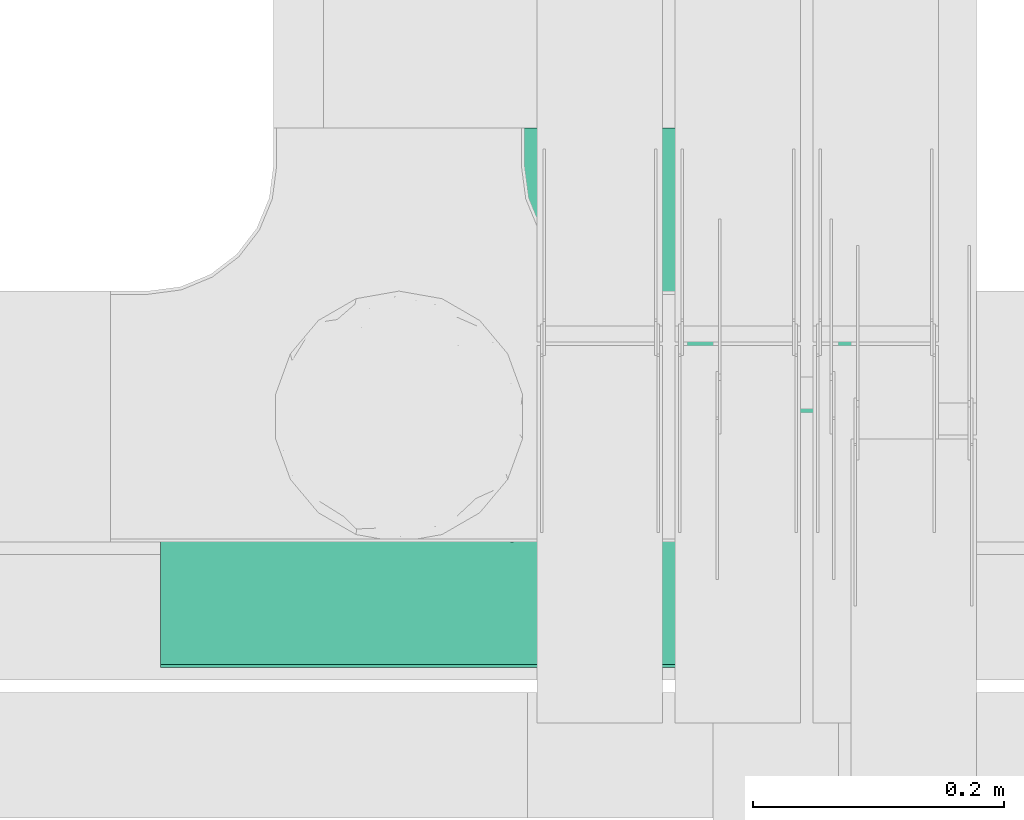
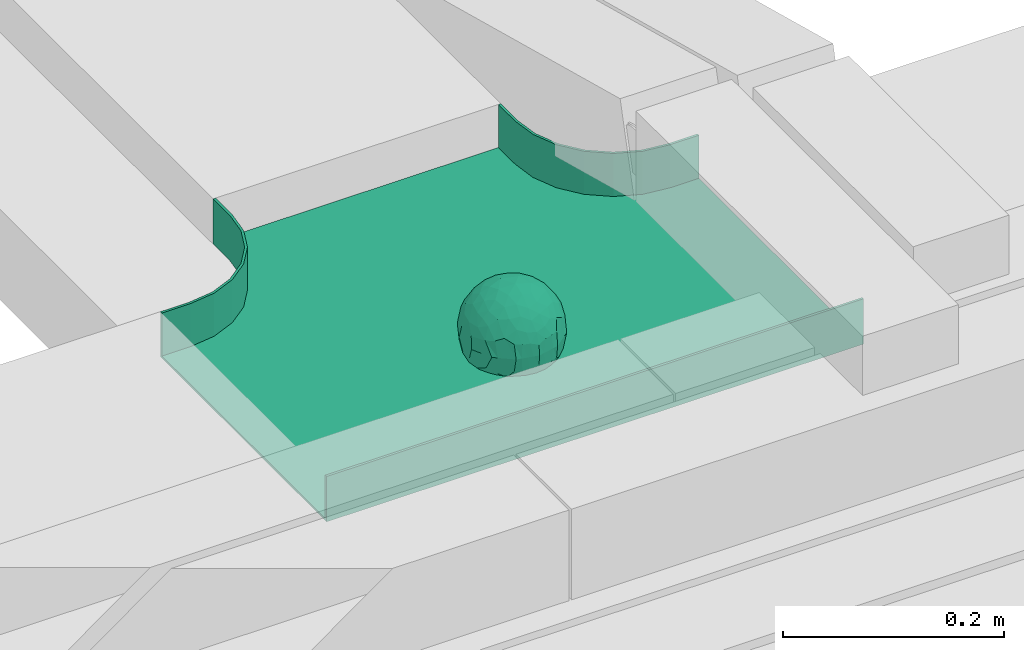
# One storey, part 32 of 33: 1 flow fitting.
"""IFC2X3 building model written with IfcOpenShell, lengths in millimetres."""

from ifc_helpers import new_model, entity, si_unit, converted_unit, derived_unit, direction, frame, origin, place, context, subcontext, project, spatial, faceted_brep, source, transform, mapped, material, material_list, type_object, type_shapes, element, save


model = new_model("IFC2X3")

# Units and contexts
model_context = context("Model", 3, precision=0.01, world=origin(), true_north=direction((6.12303176911189e-17, 1.0)))
body_context = subcontext(model_context, "Body", "Model", "MODEL_VIEW")
ifc_project = project(units=[si_unit("LENGTHUNIT", "METRE", prefix="MILLI"), si_unit("AREAUNIT", "SQUARE_METRE"), si_unit("VOLUMEUNIT", "CUBIC_METRE"), converted_unit("PLANEANGLEUNIT", "DEGREE", entity("IfcRatioMeasure", 0.0174532925199433), si_unit("PLANEANGLEUNIT", "RADIAN"), dimensions=[0, 0, 0, 0, 0, 0, 0]), si_unit("MASSUNIT", "GRAM", prefix="KILO"), derived_unit("MASSDENSITYUNIT", [(si_unit("MASSUNIT", "GRAM", prefix="KILO"), 1), (si_unit("LENGTHUNIT", "METRE"), -3)]), derived_unit("MOMENTOFINERTIAUNIT", [(si_unit("LENGTHUNIT", "METRE"), 4)]), si_unit("TIMEUNIT", "SECOND"), si_unit("FREQUENCYUNIT", "HERTZ"), si_unit("THERMODYNAMICTEMPERATUREUNIT", "DEGREE_CELSIUS"), derived_unit("THERMALTRANSMITTANCEUNIT", [(si_unit("MASSUNIT", "GRAM", prefix="KILO"), 1), (si_unit("THERMODYNAMICTEMPERATUREUNIT", "KELVIN"), -1), (si_unit("TIMEUNIT", "SECOND"), -3)]), derived_unit("VOLUMETRICFLOWRATEUNIT", [(si_unit("LENGTHUNIT", "METRE"), 3), (si_unit("TIMEUNIT", "SECOND"), -1)]), derived_unit("MASSFLOWRATEUNIT", [(si_unit("MASSUNIT", "GRAM", prefix="KILO"), 1), (si_unit("TIMEUNIT", "SECOND"), -1)]), derived_unit("ROTATIONALFREQUENCYUNIT", [(si_unit("TIMEUNIT", "SECOND"), -1)]), si_unit("ELECTRICCURRENTUNIT", "AMPERE"), si_unit("ELECTRICVOLTAGEUNIT", "VOLT"), si_unit("POWERUNIT", "WATT"), si_unit("FORCEUNIT", "NEWTON", prefix="KILO"), si_unit("ILLUMINANCEUNIT", "LUX"), si_unit("LUMINOUSFLUXUNIT", "LUMEN"), si_unit("LUMINOUSINTENSITYUNIT", "CANDELA"), derived_unit("USERDEFINED", [(si_unit("MASSUNIT", "GRAM", prefix="KILO"), -1), (si_unit("LENGTHUNIT", "METRE"), -2), (si_unit("TIMEUNIT", "SECOND"), 3), (si_unit("LUMINOUSFLUXUNIT", "LUMEN"), 1)]), derived_unit("LINEARVELOCITYUNIT", [(si_unit("LENGTHUNIT", "METRE"), 1), (si_unit("TIMEUNIT", "SECOND"), -1)]), si_unit("PRESSUREUNIT", "PASCAL"), derived_unit("USERDEFINED", [(si_unit("LENGTHUNIT", "METRE"), -2), (si_unit("MASSUNIT", "GRAM", prefix="KILO"), 1), (si_unit("TIMEUNIT", "SECOND"), -2)]), derived_unit("LINEARFORCEUNIT", [(si_unit("MASSUNIT", "GRAM", prefix="KILO"), 1), (si_unit("LENGTHUNIT", "METRE"), 1), (si_unit("TIMEUNIT", "SECOND"), -2), (si_unit("LENGTHUNIT", "METRE"), -1)]), derived_unit("PLANARFORCEUNIT", [(si_unit("MASSUNIT", "GRAM", prefix="KILO"), 1), (si_unit("LENGTHUNIT", "METRE"), 1), (si_unit("TIMEUNIT", "SECOND"), -2), (si_unit("LENGTHUNIT", "METRE"), -2)])], contexts=[model_context])

# Site, building, storey
site_placement = place(None, frame((0.0, -0.00077364408347762, 0.0)))
site = spatial("IfcSite", under=ifc_project, at=site_placement, CompositionType="ELEMENT")
building_placement = place(site_placement, origin())
building = spatial("IfcBuilding", under=site, at=building_placement, CompositionType="ELEMENT")
storey_placement = place(building_placement, frame((0.0, 0.0, 8100.0)))
storey = spatial("IfcBuildingStorey", under=building, at=storey_placement, CompositionType="ELEMENT", Elevation=8100.0)

# Flow fitting
ifc_material_1 = material()
ifc_material_2 = material()
ifc_material_list = material_list([ifc_material_1, ifc_material_2])
cable_carrier_fitting_type = type_object("IfcCableCarrierFittingType", PredefinedType="NOTDEFINED", material=ifc_material_1)
shared_shape = source(origin(), body_context, "Body", "Brep", [
    faceted_brep([(43.65414201495, -13.6159823941412, -20.221792907194), (44.7734537304832, 0.0, -22.2561865791168), (48.2627667869764, -5.5982238187369, -11.8053052540677), (16.6591030416451, 5.32882774998004, -46.8409850521773), (11.5556000970565, -8.32997143460759, -47.9278591457525), (2.01883462715812, 2.6979389970297, -49.8863250993269), (-7.81264210311725, -35.946586740035, -33.8645171988286), (-17.2052206683237, -38.2719861359275, -27.1888848422606), (-11.1277274207927, -27.3202044092451, -40.3705352142543), (37.7030088371667, -7.24923843471304, -32.0301680723234), (10.6384317789277, 26.5155476513889, -41.0335168128579), (19.2127839264957, 19.8412508508062, -41.6796556903778), (10.4192511908907, 17.8098221318595, -45.5439286870577), (48.7463956090969, 0.0, 0.0), (48.0667721403428, 6.51594663441988, -12.1296271775358), (-37.4554170352858, 12.1627069007925, -30.8084451986326), (-31.3452178059555, 12.1462454498318, -37.0127821457472), (-38.0909108580228, 3.52194087904066, -32.1974912446565), (48.7463956090969, 11.1260466978072, 0.0), (9.66670567763161, 42.5651334019307, -24.3877883338551), (17.4761229293595, 37.974251726212, -27.4324868211278), (8.3452685270067, 35.3634447252368, -34.3479733081336), (36.7018152786982, 20.4309971840494, -27.121045505536), (28.2201055605836, 12.5803931374896, -39.3110588849404), (28.3969378462537, 24.0066360557188, -33.4259681422047), (37.1036906899333, 7.75177236926259, -32.6071489449891), (30.3928805396455, 38.1114667440203, 0.0), (34.7422273315263, 34.6429784184742, 0.0), (32.9402906787036, 32.1278050479557, -19.5637775698511), (26.0435337477646, 41.5799550695664, 0.0), (-44.7734518080776, 0.0, -22.2561904464559), (-35.9183276906112, -8.71634506105637, -33.6734177755349), (-42.698067512074, -12.1858404892465, -22.9865247983333), (5.42354673897514, -48.7621108487887, 0.0), (2.92058716488888e-07, -48.7843224693665, -10.9585528791684), (7.58713024513234, -47.4313421101439, -13.8817592643935), (33.995370401777, -31.6485911362954, -18.5116576873667), (40.0066375577234, -26.2448741379086, -14.5146661281262), (30.3928805396453, -38.1114667440373, 0.0), (-47.5540080368347, -8.6499737676748, -12.798213682019), (43.918984866252, -21.1502683953847, 0.0), (-47.5463631702337, 8.67950108284767, -12.8066236860544), (-43.9189848662407, 21.1502683953677, 0.0), (-41.5587306666804, 23.544384411141, -14.7828910593852), (-36.7018137075475, 20.43099797302, -27.1210470373429), (-42.6812093094125, 12.162707383776, -23.0300438771125), (-0.0435489182880873, -44.6798423199703, -22.4434799831651), (43.3459115209922, 13.125713179152, -21.1860238825719), (-9.67158541810518, -42.815796006327, -23.9430166822217), (2.9348104480415, -38.3026865671621, -32.0045479482528), (10.5768620896568, -32.3565839798164, -36.6221444141874), (17.476122931187, -37.9742517249799, -27.4324868216925), (29.4150529887209, -14.2918330913411, -37.8219270339311), (29.2594402117981, 0.0, -40.5448536622337), (-34.742227331515, 34.6429784184742, 0.0), (-35.5934709721032, 30.8679809236437, -16.7413433706631), (16.2706402169142, 46.2863325463322, 0.0), (15.3978227309257, 45.3692296018892, -14.301750259225), (10.8470934779447, 47.524221697552, 0.0), (-22.0930685137321, 42.2576087042555, -15.0396419586498), (-16.2706402169028, 46.2863325463322, 0.0), (-15.3976096147999, 45.3685960862683, -14.3039892096614), (-35.5741674477324, -30.877857614309, -16.7641438657341), (-34.7422273315149, -34.6429784184913, 0.0), (-41.544749127214, -23.5699215759022, -14.7814957586296), (-21.2012609977656, -29.9118129495041, -33.9969113035032), (-22.0930685137892, -42.2576087036302, -15.0396419603704), (-28.5890959469058, -35.7745555449591, -20.0709932115786), (27.967317375364, -26.9235432392394, -31.5111405422078), (26.5630985649032, -36.7540375314827, -21.0604491824418), (-4.69743067705244, -12.8233951627736, -48.0988012484001), (-3.71385705669819, -22.0483048804436, -44.7222485756373), (7.046128924104e-07, -29.8515321197025, -40.1109215813634), (-8.78090686085946, 23.4705297392872, -43.266960933916), (-10.7087237416586, 12.1533783795858, -47.3034737602475), (-19.1851128431225, 19.8122800241045, -41.7061746680507), (19.2127839279743, -19.841250849511, -41.6796556903208), (10.2736167511021, -43.2535488218696, -22.8819429499797), (-16.2706402169027, -46.2863325463492, 0.0), (-15.4179487650123, -45.4307793041134, -14.0830091848577), (-10.8470934779332, -47.524221697569, 0.0), (-21.6941869558721, -45.0484433951294, 0.0), (-26.043533747753, -41.5799550695834, 0.0), (-30.3928805396339, -38.1114667440373, 0.0), (-26.9077773704145, -11.7097120961444, -40.4827637348157), (-28.5735237959864, -22.531789977659, -34.2909926698312), (-14.3485559949731, 0.554718003800719, -47.8937493708156), (20.3912706461748, 29.6966950280778, -34.6742323035854), (25.8798715159051, 35.5620355309087, -23.7817972243053), (-1.90439589452332, 38.2956374757213, -32.090768557389), (-0.0435489197807358, 44.6798423204566, -22.4434799821603), (-9.54280395759116, 42.6678856642021, -24.2566779582937), (-10.1209262269152, 33.0365306692783, -36.140759450321), (-17.2052206685055, 38.2719861378047, -27.1888848394794), (-28.5890959468196, 35.7745555453602, -20.0709932109564), (-30.3928805396341, 38.1114667440203, 0.0), (-26.0435337477532, 41.5799550695664, 0.0), (-21.6941869558723, 45.0484433951125, 0.0), (0.920553890736952, 16.9936143333855, -47.0145685125519), (7.01705705346737e-07, 29.8515321215381, -40.1109215799846), (-28.4299335912282, 23.6392950735915, -33.6589156750601), (22.0754283900311, -42.7194435884069, -13.7012627481666), (0.0, -50.0, 0.0), (-7.98433520770671, 47.2879675743241, -14.1456181900809), (-10.8470934779333, 47.524221697552, 0.0), (-5.42354673896381, 48.7621108487718, 0.0), (-39.0915741233958, -31.1744900929452, 0.0), (-36.7018137083218, -20.4309979729983, -27.1210470363242), (-20.0503020227076, 29.8835350153312, -34.7125297808217), (48.7463956090969, -11.1260466978243, 0.0), (36.7018152787698, -20.430997183803, -27.1210455056374), (39.0915741234071, -31.1744900929452, 0.0), (43.9189848662521, 21.1502683953677, 0.0), (41.0372234357161, 24.481336168204, -14.7176924857918), (21.4315363761966, -9.86715979165204, -44.0831986838696), (19.8461085062156, -30.3026908878047, -34.4656191315041), (26.0435337477644, -41.5799550695834, 0.0), (8.27678352490751, -22.6176025005053, -43.8171075221857), (-19.1851128386707, -19.8122800229913, -41.7061746706354), (-17.559283921422, -9.66340012518247, -45.8070982074481), (-29.2594384269524, -1.64502744759432e-09, -40.5448549502702), (-22.2759109836818, 8.45458562997746, -43.957977338265), (21.6941869558835, -45.0484433951294, 0.0), (-7.7537430917927, -47.3248906716555, -14.1504131029038), (22.0929359888287, 42.3611643932195, -14.7456410726513), (21.6941869558837, 45.0484433951125, 0.0), (7.94480963874029, 47.2524194975214, -14.285966940796), (5.42354673897518, 48.7621108487718, 0.0), (-43.9189848662406, -21.1502683953848, 0.0), (-39.0915741233959, 31.1744900929281, 0.0), (-48.7463956090855, 11.1260466978072, 0.0), (-48.7463956090855, -11.1260466978243, 0.0), (-48.7463956090855, 0.0, 0.0), (0.0, 50.0, 0.0), (2.95674852821199e-07, 48.76542105366, -11.0423597776141), (-5.42354673896377, -48.7621108487887, 0.0), (16.2706402169141, -46.2863325463492, 0.0), (10.8470934779446, -47.524221697569, 0.0), (39.0915741234072, 31.1744900929281, 0.0), (34.7422273315262, -34.6429784184913, 0.0), (-43.6541417785539, -13.6159824952714, 20.2217933494142), (-44.7734534735007, 0.0, 22.2561870960884), (-48.2627667188257, -5.59822380837423, 11.8053055375658), (-16.6591016552529, 5.32882757852047, 46.8409855647676), (-11.5555985538933, -8.32997141356845, 47.9278595214841), (-2.01883285210585, 2.69793886619285, 49.8863251782511), (7.81264298940045, -35.9465866899564, 33.8645170475355), (17.2052219498432, -38.2719853643866, 27.1888851173795), (11.1277291939633, -27.3202042660781, 40.370534822402), (-37.7030082707847, -7.24923849358482, 32.0301687256941), (-10.6384306361632, 26.5155474098453, 41.0335172652288), (-19.2127828542464, 19.8412506695278, 41.6796562709507), (-10.419249902145, 17.8098220464058, 45.5439290153173), (-48.0667720467311, 6.51594672713361, 12.1296274986609), (37.4554198551597, 12.1627053911885, 30.8084423663635), (31.3452204336626, 12.1462444514283, 37.0127802480704), (38.0909129847824, 3.52193921618223, 32.1974889105362), (-9.66670492251031, 42.565133342123, 24.3877887375616), (-17.4761222809685, 37.9742516795029, 27.4324872988574), (-8.34526747232003, 35.3634445391436, 34.3479737559899), (-36.7018147879525, 20.4309972885889, 27.1210460908894), (-28.2201045883605, 12.5803929822385, 39.3110596325575), (-28.3969371324566, 24.0066357536882, 33.4259689655335), (-37.1036900366786, 7.75177247673037, 32.6071496627812), (-32.9402901163369, 32.1278052689131, 19.5637781538672), (44.773453728735, 0.0, 22.2561865826485), (35.9183286182219, -8.71634518545332, 33.6734167539099), (42.6980684782056, -12.1858381773451, 22.9865242293622), (-5.1564557811304e-08, -48.7843224155168, 10.9585531189064), (-7.58712982046247, -47.4313421866568, 13.8817592350767), (-33.9953700157816, -31.6485912778883, 18.5116581541388), (-40.0066373233245, -26.2448743223541, 14.5146664406737), (47.5540088657557, -8.64997340643016, 12.7982108462298), (47.5463641063755, 8.67950029611492, 12.8066207437518), (41.5587323717035, 23.5443822102692, 14.7828897714275), (36.7018153946169, 20.4309968399072, 27.121045607934), (42.6812105193328, 12.1627054070682, 23.0300426787683), (0.0435498934198039, -44.6798421141237, 22.4434803910813), (-43.3459112327239, 13.1257132261269, 21.1860244432478), (9.6715868653752, -42.8157959611257, 23.9430161784588), (-2.93481023367521, -38.3026862522726, 32.0045483447802), (-10.5768615382775, -32.3565831315815, 36.6221453228799), (-17.4761222811971, -37.9742516793303, 27.4324872989742), (-29.4150522011614, -14.2918331221065, 37.8219276348162), (-29.259439267976, 0.0, 40.5448543433553), (35.593472529025, 30.867979902287, 16.7413419437535), (-15.3978225621776, 45.3692295068837, 14.3017507422931), (22.0930688164668, 42.2576085856364, 15.0396418472572), (15.3976099169387, 45.3685960801975, 14.3039889037045), (35.5741692798952, -30.8778564526781, 16.7641421174582), (41.5447510295928, -23.5699190140567, 14.7814944968718), (21.2012629219892, -29.9118119699372, 33.9969109653959), (22.0930688164889, -42.2576085855628, 15.039641847479), (28.5890966709526, -35.7745557157875, 20.0709918757936), (-27.9673166448933, -26.9235432178776, 31.5111412087844), (-26.5630981091642, -36.7540374223405, 21.0604499477277), (4.69743244094294, -12.8233948182002, 48.0988011680158), (3.71385918047916, -22.0483045188225, 44.7222485775695), (6.0892732202368e-07, -29.8515316280668, 40.1109219472655), (8.78090833347225, 23.4705290601204, 43.2669610034903), (10.7087255323208, 12.1533779204354, 47.3034734728551), (19.1851144535653, 19.8122792782791, 41.7061742815566), (-19.212782854423, -19.8412506693283, 41.6796562709723), (-10.2736163541564, -43.2535491498667, 22.8819425082012), (15.4179491053271, -45.430779442795, 14.0830083649343), (26.9077783310918, -11.7097109554472, 40.4827634262511), (28.5735255699879, -22.531788297607, 34.2909922955619), (14.3485579041194, 0.554717908736034, 47.893748799971), (-20.3912698186306, 29.6966949125693, 34.674232889184), (-25.8798708903081, 35.5620354347035, 23.7817980489561), (1.90439718168615, 38.2956370656312, 32.0907689704016), (0.0435498935700709, 44.6798421141929, 22.4434803909095), (9.54280511870019, 42.6678852802435, 24.2566781769111), (10.1209277017953, 33.036529901429, 36.1407597392074), (17.2052219497738, 38.2719853646937, 27.1888851169673), (28.5890966709116, 35.7745557157488, 20.0709918758907), (-0.920552500958269, 16.993613961591, 47.0145686741652), (6.09264554473049e-07, 29.8515316283504, 40.1109219470418), (28.4299352793349, 23.6392936643312, 33.6589152389788), (-22.0754282965694, -42.7194435788052, 13.7012629286858), (7.9843354212563, 47.2879674404261, 14.1456185171795), (36.7018153946056, -20.4309968401043, 27.1210456078136), (20.0503035663584, 29.8835340747136, 34.7125296989797), (-36.7018147879654, -20.4309972885437, 27.1210460909186), (-41.0372232425556, 24.4813362747081, 14.7176928472045), (-21.4315352776288, -9.8671595900376, 44.0831992630873), (-19.8461080318002, -30.3026912052829, 34.4656191255603), (-8.27678185920825, -22.617601585775, 43.8171083090061), (19.1851144530605, -19.8122792780652, 41.7061742818985), (17.5592847966676, -9.6634000411993, 45.8070978896755), (29.259440221343, 0.0, 40.5448536553604), (22.2759127990671, 8.45458631346954, 43.9579762868721), (7.75374356219277, -47.3248906381916, 14.1504129570858), (-22.0929358819219, 42.3611643749655, 14.7456412852645), (-7.94480944914509, 47.2524194744515, 14.2859671225497), (-5.23333520595152e-08, 48.7654210084985, 11.0423599770715)], [[[0, 1, 2]], [[3, 4, 5]], [[6, 7, 8]], [[1, 0, 9]], [[10, 11, 12]], [[13, 2, 14]], [[15, 16, 17]], [[14, 18, 13]], [[19, 20, 21]], [[22, 23, 24]], [[1, 9, 25]], [[26, 27, 28, 29]], [[30, 31, 32]], [[33, 34, 35]], [[36, 37, 38]], [[32, 39, 30]], [[2, 40, 0]], [[23, 22, 25]], [[41, 42, 43]], [[44, 15, 45]], [[46, 35, 34]], [[25, 22, 47]], [[31, 30, 17]], [[48, 49, 46]], [[50, 51, 49]], [[52, 53, 9]], [[43, 54, 55]], [[56, 57, 58]], [[59, 60, 61]], [[62, 63, 64]], [[8, 7, 65]], [[7, 66, 67]], [[68, 36, 69]], [[70, 5, 4]], [[8, 71, 72]], [[73, 74, 75]], [[68, 76, 52]], [[77, 46, 49]], [[78, 79, 80]], [[7, 6, 48]], [[67, 81, 82, 83]], [[84, 85, 31]], [[85, 65, 67]], [[70, 86, 5]], [[23, 3, 11]], [[21, 87, 10]], [[21, 20, 87]], [[28, 24, 88]], [[19, 89, 90]], [[91, 90, 89]], [[91, 92, 93]], [[94, 95, 96, 97]], [[98, 99, 10]], [[100, 16, 44]], [[77, 51, 101]], [[33, 102, 34]], [[103, 91, 61]], [[93, 59, 61]], [[104, 105, 103]], [[106, 64, 63]], [[107, 31, 85]], [[100, 94, 108]], [[108, 93, 92]], [[43, 55, 44]], [[0, 40, 37]], [[2, 13, 109]], [[2, 1, 14]], [[110, 9, 0]], [[2, 109, 40]], [[37, 40, 111]], [[47, 14, 1]], [[112, 14, 47]], [[113, 112, 47]], [[112, 18, 14]], [[47, 22, 113]], [[52, 9, 110]], [[53, 25, 9]], [[25, 47, 1]], [[23, 25, 53]], [[68, 52, 110]], [[76, 4, 114]], [[51, 115, 69]], [[50, 115, 51]], [[110, 36, 68]], [[3, 23, 53]], [[23, 11, 24]], [[52, 76, 114]], [[98, 12, 5]], [[11, 87, 24]], [[24, 28, 22]], [[87, 88, 24]], [[36, 116, 69]], [[28, 27, 113]], [[114, 3, 53]], [[76, 115, 117]], [[70, 4, 117]], [[118, 84, 119]], [[119, 70, 118]], [[120, 16, 121]], [[37, 36, 110]], [[116, 36, 38]], [[116, 122, 69]], [[34, 123, 46]], [[10, 87, 11]], [[87, 20, 88]], [[12, 98, 10]], [[10, 99, 21]], [[74, 5, 86]], [[73, 75, 108]], [[124, 56, 125]], [[124, 29, 88]], [[89, 21, 99]], [[21, 89, 19]], [[92, 89, 99]], [[89, 92, 91]], [[126, 127, 58]], [[88, 29, 28]], [[20, 57, 124]], [[88, 20, 124]], [[57, 20, 19]], [[73, 92, 99]], [[92, 73, 108]], [[99, 98, 73]], [[74, 86, 121]], [[73, 98, 74]], [[5, 74, 98]], [[100, 108, 75]], [[94, 93, 108]], [[86, 120, 121]], [[100, 44, 55]], [[75, 16, 100]], [[17, 16, 120]], [[31, 17, 120]], [[17, 30, 45]], [[84, 31, 120]], [[31, 107, 32]], [[41, 45, 30]], [[43, 44, 45]], [[107, 64, 32]], [[39, 64, 128]], [[30, 39, 41]], [[129, 43, 42]], [[41, 130, 42]], [[43, 45, 41]], [[62, 83, 63]], [[95, 94, 55]], [[100, 55, 94]], [[64, 107, 62]], [[131, 39, 128]], [[64, 106, 128]], [[85, 62, 107]], [[67, 83, 62]], [[39, 32, 64]], [[130, 41, 132]], [[59, 97, 60]], [[133, 127, 134]], [[59, 94, 97]], [[104, 61, 60]], [[94, 59, 93]], [[126, 134, 127]], [[126, 58, 57]], [[19, 90, 126]], [[134, 105, 133]], [[126, 90, 134]], [[103, 90, 91]], [[105, 134, 103]], [[90, 103, 134]], [[119, 120, 86]], [[84, 118, 85]], [[65, 85, 118]], [[62, 85, 67]], [[8, 65, 118]], [[67, 65, 7]], [[71, 118, 70]], [[8, 72, 6]], [[49, 6, 72]], [[6, 49, 48]], [[50, 49, 72]], [[77, 49, 51]], [[101, 69, 122]], [[123, 34, 135]], [[101, 122, 136]], [[137, 77, 136]], [[78, 81, 66]], [[7, 79, 66]], [[67, 66, 81]], [[79, 7, 48]], [[35, 137, 33]], [[123, 80, 79]], [[135, 34, 102]], [[35, 46, 77]], [[80, 123, 135]], [[46, 123, 48]], [[117, 50, 72]], [[115, 76, 68]], [[117, 72, 71]], [[4, 76, 117]], [[39, 132, 41]], [[39, 131, 132]], [[137, 35, 77]], [[124, 57, 56]], [[126, 57, 19]], [[103, 61, 104]], [[61, 91, 93]], [[77, 101, 136]], [[51, 69, 101]], [[28, 113, 22]], [[112, 113, 138]], [[16, 75, 121]], [[74, 121, 75]], [[66, 79, 78]], [[123, 79, 48]], [[0, 37, 110]], [[37, 111, 139, 38]], [[29, 124, 125]], [[115, 50, 117]], [[69, 115, 68]], [[120, 119, 84]], [[70, 119, 86]], [[11, 3, 12]], [[5, 12, 3]], [[118, 71, 8]], [[117, 71, 70]], [[3, 114, 4]], [[53, 52, 114]], [[27, 138, 113]], [[45, 15, 17]], [[44, 16, 15]], [[55, 54, 95]], [[43, 129, 54]], [[140, 141, 142]], [[143, 144, 145]], [[146, 147, 148]], [[141, 140, 149]], [[150, 151, 152]], [[132, 142, 153]], [[154, 155, 156]], [[153, 130, 132]], [[157, 158, 159]], [[160, 161, 162]], [[141, 149, 163]], [[95, 54, 164, 96]], [[165, 166, 167]], [[135, 168, 169]], [[170, 171, 83]], [[167, 172, 165]], [[142, 141, 153]], [[161, 160, 163]], [[173, 112, 174]], [[175, 154, 176]], [[177, 169, 168]], [[163, 160, 178]], [[166, 165, 156]], [[179, 180, 177]], [[181, 182, 180]], [[183, 184, 149]], [[174, 27, 185]], [[60, 186, 104]], [[187, 56, 188]], [[189, 139, 190]], [[148, 147, 191]], [[147, 192, 193]], [[194, 170, 195]], [[196, 145, 144]], [[148, 197, 198]], [[199, 200, 201]], [[194, 202, 183]], [[203, 177, 180]], [[136, 204, 137]], [[147, 146, 179]], [[193, 122, 116, 38]], [[205, 206, 166]], [[206, 191, 193]], [[196, 207, 145]], [[161, 143, 151]], [[159, 208, 150]], [[159, 158, 208]], [[164, 162, 209]], [[157, 210, 211]], [[212, 211, 210]], [[212, 213, 214]], [[215, 26, 29, 125]], [[216, 217, 150]], [[218, 155, 175]], [[203, 182, 219]], [[135, 102, 168]], [[220, 212, 188]], [[214, 187, 188]], [[58, 127, 220]], [[111, 190, 139]], [[221, 166, 206]], [[218, 215, 222]], [[222, 214, 213]], [[174, 185, 175]], [[171, 140, 128]], [[132, 131, 142]], [[142, 128, 140]], [[223, 149, 140]], [[142, 131, 128]], [[171, 128, 106]], [[178, 153, 141]], [[42, 153, 178]], [[224, 42, 178]], [[42, 130, 153]], [[178, 160, 224]], [[183, 149, 223]], [[184, 163, 149]], [[163, 178, 141]], [[161, 163, 184]], [[194, 183, 223]], [[202, 144, 225]], [[182, 226, 195]], [[181, 226, 182]], [[223, 170, 194]], [[143, 161, 184]], [[161, 151, 162]], [[183, 202, 225]], [[216, 152, 145]], [[151, 208, 162]], [[162, 164, 160]], [[208, 209, 162]], [[170, 82, 195]], [[164, 54, 224]], [[225, 143, 184]], [[202, 226, 227]], [[196, 144, 227]], [[228, 205, 229]], [[229, 196, 228]], [[230, 155, 231]], [[171, 170, 223]], [[82, 170, 83]], [[82, 81, 195]], [[168, 232, 177]], [[150, 208, 151]], [[208, 158, 209]], [[152, 216, 150]], [[150, 217, 159]], [[200, 145, 207]], [[199, 201, 222]], [[233, 60, 97]], [[233, 96, 209]], [[210, 159, 217]], [[159, 210, 157]], [[213, 210, 217]], [[210, 213, 212]], [[234, 105, 104]], [[209, 96, 164]], [[158, 186, 233]], [[209, 158, 233]], [[186, 158, 157]], [[199, 213, 217]], [[213, 199, 222]], [[217, 216, 199]], [[200, 207, 231]], [[199, 216, 200]], [[145, 200, 216]], [[218, 222, 201]], [[215, 214, 222]], [[207, 230, 231]], [[218, 175, 185]], [[201, 155, 218]], [[156, 155, 230]], [[166, 156, 230]], [[156, 165, 176]], [[205, 166, 230]], [[166, 221, 167]], [[173, 176, 165]], [[174, 175, 176]], [[221, 190, 167]], [[172, 190, 40]], [[165, 172, 173]], [[138, 174, 112]], [[173, 18, 112]], [[174, 176, 173]], [[189, 38, 139]], [[26, 215, 185]], [[218, 185, 215]], [[190, 221, 189]], [[109, 172, 40]], [[190, 111, 40]], [[206, 189, 221]], [[193, 38, 189]], [[172, 167, 190]], [[18, 173, 13]], [[187, 125, 56]], [[133, 105, 235]], [[187, 215, 125]], [[58, 188, 56]], [[215, 187, 214]], [[234, 235, 105]], [[234, 104, 186]], [[157, 211, 234]], [[235, 127, 133]], [[234, 211, 235]], [[220, 211, 212]], [[127, 235, 220]], [[211, 220, 235]], [[229, 230, 207]], [[205, 228, 206]], [[191, 206, 228]], [[189, 206, 193]], [[148, 191, 228]], [[193, 191, 147]], [[197, 228, 196]], [[148, 198, 146]], [[180, 146, 198]], [[146, 180, 179]], [[181, 180, 198]], [[203, 180, 182]], [[219, 195, 81]], [[232, 168, 33]], [[219, 81, 78]], [[80, 203, 78]], [[136, 122, 192]], [[147, 204, 192]], [[193, 192, 122]], [[204, 147, 179]], [[169, 80, 135]], [[232, 137, 204]], [[33, 168, 102]], [[169, 177, 203]], [[137, 232, 33]], [[177, 232, 179]], [[227, 181, 198]], [[226, 202, 194]], [[227, 198, 197]], [[144, 202, 227]], [[172, 13, 173]], [[172, 109, 13]], [[80, 169, 203]], [[233, 186, 60]], [[234, 186, 157]], [[220, 188, 58]], [[188, 212, 214]], [[203, 219, 78]], [[182, 195, 219]], [[164, 224, 160]], [[42, 224, 129]], [[155, 201, 231]], [[200, 231, 201]], [[192, 204, 136]], [[232, 204, 179]], [[140, 171, 223]], [[171, 106, 63, 83]], [[96, 233, 97]], [[226, 181, 227]], [[195, 226, 194]], [[230, 229, 205]], [[196, 229, 207]], [[151, 143, 152]], [[145, 152, 143]], [[228, 197, 148]], [[227, 197, 196]], [[143, 225, 144]], [[184, 183, 225]], [[54, 129, 224]], [[176, 154, 156]], [[175, 155, 154]], [[185, 27, 26]], [[174, 138, 27]]]),
    faceted_brep([(280.0, -150.0, 25.0), (280.0, -147.460000010164, 25.0), (250.0, -147.460000010164, 25.0), (223.460695117866, -150.953965782136, 25.0), (198.730000005124, -161.197755104745, 25.0), (177.493270664353, -177.493270664316, 25.0), (161.197755104772, -198.730000005079, 25.0), (150.953965782152, -223.460695117816, 25.0), (147.460000010167, -250.0, 25.0), (147.460000010167, -280.0, 25.0), (150.0, -280.0, 25.0), (150.0, -250.0, 25.0), (153.407417371111, -224.118095489747, 25.0), (163.397459621585, -200.0, 25.0), (179.289321881382, -179.289321881346, 25.0), (200.0, -163.397459621558, 25.0), (224.118095489797, -153.407417371097, 25.0), (250.0, -150.0, 25.0), (-153.407417371086, -224.118095489752, 25.0), (-150.0, -250.0, 25.0), (-150.0, -280.0, 25.0), (-147.460000010153, -280.0, 25.0), (-147.460000010153, -250.0, 25.0), (-150.953965782126, -223.460695117822, 25.0), (-161.197755104736, -198.730000005084, 25.0), (-177.49327066431, -177.493270664319, 25.0), (-198.730000005075, -161.197755104746, 25.0), (-223.460695117813, -150.953965782136, 25.0), (-250.0, -147.460000010164, 25.0), (-280.0, -147.460000010164, 25.0), (-280.0, -150.0, 25.0), (-250.0, -150.0, 25.0), (-224.118095489745, -153.407417371098, 25.0), (-200.0, -163.39745962156, 25.0), (-179.28932188134, -179.289321881349, 25.0), (-163.397459621549, -200.0, 25.0), (280.0, 147.460000010155, 25.0), (280.0, 150.0, 25.0), (-280.0, 150.0, 25.0), (-280.0, 147.460000010155, 25.0), (-280.0, -150.0, -25.0), (-280.0, 150.0, -25.0), (280.0, 150.0, -25.0), (280.0, -150.0, -25.0), (250.0, -150.0, -25.0), (224.118095489797, -153.407417371097, -25.0), (200.0, -163.397459621558, -25.0), (179.289321881382, -179.289321881346, -25.0), (163.397459621585, -200.0, -25.0), (153.407417371111, -224.118095489747, -25.0), (150.0, -250.0, -25.0), (150.0, -280.0, -25.0), (-150.0, -280.0, -25.0), (-150.0, -250.0, -25.0), (-153.407417371086, -224.118095489752, -25.0), (-163.397459621549, -200.0, -25.0), (-179.28932188134, -179.289321881349, -25.0), (-200.0, -163.39745962156, -25.0), (-224.118095489745, -153.407417371098, -25.0), (-250.0, -150.0, -25.0), (-150.0, -250.0, -22.4600000101619), (147.460000010167, -280.0, -22.4600000101619), (-147.460000010153, -280.0, -22.4600000101619), (-147.460000010153, -250.0, -22.4600000101619), (-250.0, -147.460000010164, -22.4600000101619), (-280.0, -147.460000010164, -22.4600000101619), (280.0, -147.460000010164, -22.4600000101619), (250.0, -147.460000010164, -22.4600000101619), (-280.0, 147.460000010155, -22.4600000101619), (-250.0, -150.0, -22.4600000101619), (250.0, -150.0, -22.4600000101619), (280.0, 147.460000010155, -22.4600000101619), (147.460000010167, -250.0, -22.4600000101619), (150.0, -250.0, -22.4600000101619), (-223.460695117813, -150.953965782136, -22.4600000101619), (-198.730000005075, -161.197755104746, -22.4600000101619), (-177.49327066431, -177.493270664319, -22.4600000101619), (-161.197755104736, -198.730000005084, -22.4600000101619), (-150.953965782126, -223.460695117822, -22.4600000101619), (150.953965782151, -223.460695117817, -22.4600000101619), (161.197755104771, -198.73000000508, -22.4600000101619), (177.493270664353, -177.493270664316, -22.4600000101619), (198.730000005123, -161.197755104745, -22.4600000101619), (223.460695117865, -150.953965782137, -22.4600000101619)], [[[0, 1, 2, 3, 4, 5, 6, 7, 8, 9, 10, 11, 12, 13, 14, 15, 16, 17]], [[18, 19, 20, 21, 22, 23, 24, 25, 26, 27, 28, 29, 30, 31, 32, 33, 34, 35]], [[36, 37, 38, 39]], [[40, 41, 42, 43, 44, 45, 46, 47, 48, 49, 50, 51, 52, 53, 54, 55, 56, 57, 58, 59]], [[20, 19, 60, 53, 52]], [[21, 20, 52, 51, 10, 9, 61, 62]], [[22, 21, 62, 63]], [[29, 28, 64, 65]], [[2, 1, 66, 67]], [[39, 38, 41, 40, 30, 29, 65, 68]], [[31, 30, 40, 59, 69]], [[0, 17, 70, 44, 43]], [[1, 0, 43, 42, 37, 36, 71, 66]], [[9, 8, 72, 61]], [[11, 10, 51, 50, 73]], [[38, 37, 42, 41]], [[36, 39, 68, 71]], [[68, 65, 64, 74, 75, 76, 77, 78, 63, 62, 61, 72, 79, 80, 81, 82, 83, 67, 66, 71]], [[32, 31, 69, 59, 58]], [[58, 57, 33, 32]], [[33, 57, 56, 34]], [[18, 35, 55, 54]], [[18, 54, 53, 60, 19]], [[55, 35, 34, 56]], [[23, 22, 63, 78]], [[24, 23, 78, 77]], [[25, 24, 77, 76]], [[26, 25, 76, 75]], [[27, 26, 75, 74]], [[28, 27, 74, 64]], [[3, 2, 67, 83]], [[4, 3, 83, 82]], [[5, 4, 82, 81]], [[6, 5, 81, 80]], [[7, 6, 80, 79]], [[72, 8, 7, 79]], [[12, 11, 73, 50, 49]], [[13, 12, 49, 48]], [[13, 48, 47, 14]], [[15, 14, 47, 46]], [[45, 16, 15, 46]], [[16, 45, 44, 70, 17]]]),
])
type_shapes(cable_carrier_fitting_type, [shared_shape])
flow_fitting_placement = place(storey_placement, frame((60450.1085349485, 9019.97860618824, 2813.91979567565), z_axis=(0.0, 0.0, 1.0), x_axis=(-1.0, 0.0, 0.0)))
element("IfcFlowFitting", 1, at=flow_fitting_placement, inside=storey, type_object=cable_carrier_fitting_type, material=ifc_material_list, Name="470_DKC_S5_T", context=body_context, shape_type="MappedRepresentation", body=[
    mapped(shared_shape, transform((0.0, 0.0, 0.0), scale=1.0)),
])

save(model, "model.ifc")
